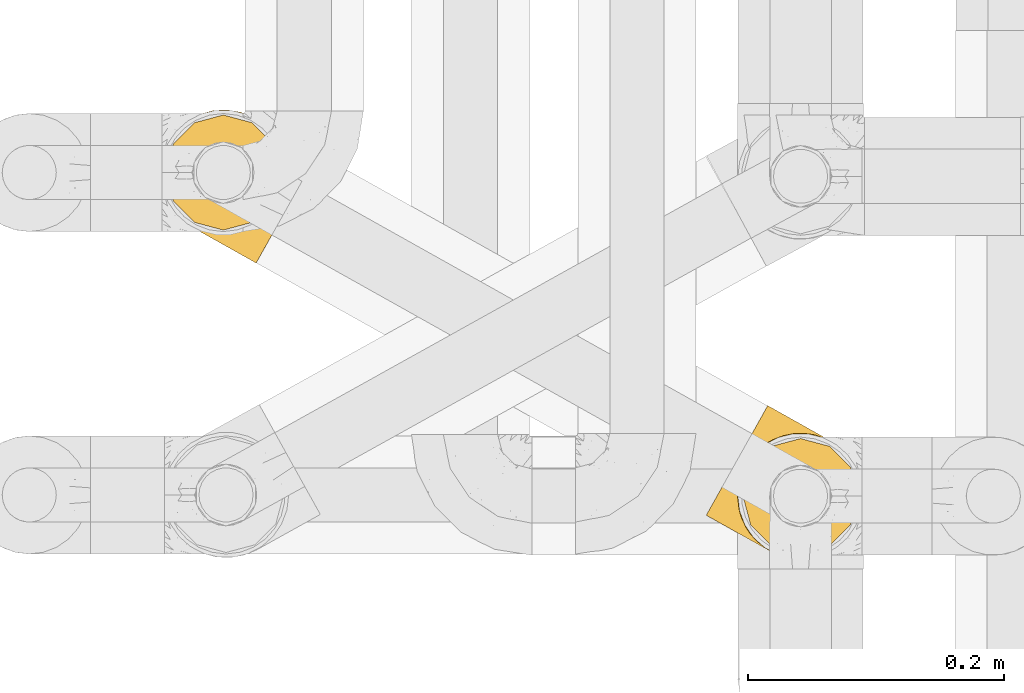
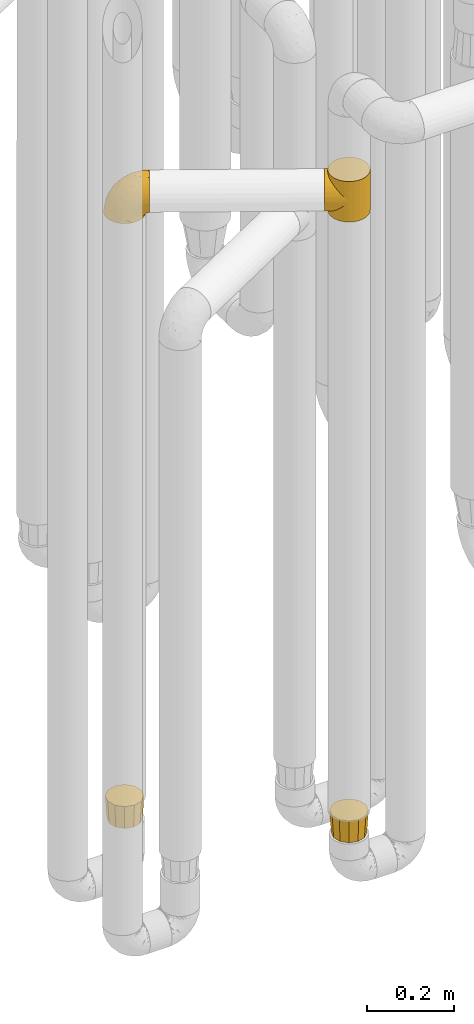
# One storey, part 155 of 827: 4 coverings.
"""IFC2X3 building model written with IfcOpenShell, lengths in millimetres."""

from ifc_helpers import new_model, entity, si_unit, converted_unit, derived_unit, direction, frame, origin, place, context, subcontext, project, spatial, faceted_brep, element, save


model = new_model("IFC2X3")

# Units and contexts
model_context = context("Model", 3, precision=0.01, world=origin(), true_north=direction((6.12303176911189e-17, 1.0)))
body_context = subcontext(model_context, "Body", "Model", "MODEL_VIEW")
ifc_project = project(units=[si_unit("LENGTHUNIT", "METRE", prefix="MILLI"), si_unit("AREAUNIT", "SQUARE_METRE"), si_unit("VOLUMEUNIT", "CUBIC_METRE"), converted_unit("PLANEANGLEUNIT", "DEGREE", entity("IfcRatioMeasure", 0.0174532925199433), si_unit("PLANEANGLEUNIT", "RADIAN"), dimensions=[0, 0, 0, 0, 0, 0, 0]), si_unit("MASSUNIT", "GRAM", prefix="KILO"), derived_unit("MASSDENSITYUNIT", [(si_unit("MASSUNIT", "GRAM", prefix="KILO"), 1), (si_unit("LENGTHUNIT", "METRE"), -3)]), derived_unit("MOMENTOFINERTIAUNIT", [(si_unit("LENGTHUNIT", "METRE"), 4)]), si_unit("TIMEUNIT", "SECOND"), si_unit("FREQUENCYUNIT", "HERTZ"), si_unit("THERMODYNAMICTEMPERATUREUNIT", "DEGREE_CELSIUS"), derived_unit("THERMALTRANSMITTANCEUNIT", [(si_unit("MASSUNIT", "GRAM", prefix="KILO"), 1), (si_unit("THERMODYNAMICTEMPERATUREUNIT", "KELVIN"), -1), (si_unit("TIMEUNIT", "SECOND"), -3)]), derived_unit("VOLUMETRICFLOWRATEUNIT", [(si_unit("LENGTHUNIT", "METRE"), 3), (si_unit("TIMEUNIT", "SECOND"), -1)]), derived_unit("MASSFLOWRATEUNIT", [(si_unit("MASSUNIT", "GRAM", prefix="KILO"), 1), (si_unit("TIMEUNIT", "SECOND"), -1)]), derived_unit("ROTATIONALFREQUENCYUNIT", [(si_unit("TIMEUNIT", "SECOND"), -1)]), si_unit("ELECTRICCURRENTUNIT", "AMPERE"), si_unit("ELECTRICVOLTAGEUNIT", "VOLT"), si_unit("POWERUNIT", "WATT"), si_unit("FORCEUNIT", "NEWTON", prefix="KILO"), si_unit("ILLUMINANCEUNIT", "LUX"), si_unit("LUMINOUSFLUXUNIT", "LUMEN"), si_unit("LUMINOUSINTENSITYUNIT", "CANDELA"), derived_unit("USERDEFINED", [(si_unit("MASSUNIT", "GRAM", prefix="KILO"), -1), (si_unit("LENGTHUNIT", "METRE"), -2), (si_unit("TIMEUNIT", "SECOND"), 3), (si_unit("LUMINOUSFLUXUNIT", "LUMEN"), 1)]), derived_unit("LINEARVELOCITYUNIT", [(si_unit("LENGTHUNIT", "METRE"), 1), (si_unit("TIMEUNIT", "SECOND"), -1)]), si_unit("PRESSUREUNIT", "PASCAL"), derived_unit("USERDEFINED", [(si_unit("LENGTHUNIT", "METRE"), -2), (si_unit("MASSUNIT", "GRAM", prefix="KILO"), 1), (si_unit("TIMEUNIT", "SECOND"), -2)]), derived_unit("LINEARFORCEUNIT", [(si_unit("MASSUNIT", "GRAM", prefix="KILO"), 1), (si_unit("LENGTHUNIT", "METRE"), 1), (si_unit("TIMEUNIT", "SECOND"), -2), (si_unit("LENGTHUNIT", "METRE"), -1)]), derived_unit("PLANARFORCEUNIT", [(si_unit("MASSUNIT", "GRAM", prefix="KILO"), 1), (si_unit("LENGTHUNIT", "METRE"), 1), (si_unit("TIMEUNIT", "SECOND"), -2), (si_unit("LENGTHUNIT", "METRE"), -2)])], contexts=[model_context])

# Site, building, storey
site_placement = place(None, origin())
site = spatial("IfcSite", under=ifc_project, at=site_placement, CompositionType="ELEMENT")
building_placement = place(site_placement, origin())
building = spatial("IfcBuilding", under=site, at=building_placement, CompositionType="ELEMENT")
storey_placement = place(building_placement, frame((0.0, 0.0, 28200.0)))
storey = spatial("IfcBuildingStorey", under=building, at=storey_placement, Name="08", CompositionType="ELEMENT", Elevation=28200.0)

# Coverings
covering_1_placement = place(storey_placement, frame((35652.7, 10305.43, 2248.0)))
element("IfcCovering", 1, at=covering_1_placement, inside=storey, Name=":ADSK_", ObjectType=":ADSK_", PredefinedType="INSULATION", context=body_context, shape_type="Brep", body=[
    faceted_brep([(45.76, 11.5, 63.62), (51.31, 7.87, 114.0), (41.04, 15.55, 114.0), (33.1, 25.63, 114.0), (36.21, 21.01, 76.6), (29.32, 33.5, 88.72), (28.04, 37.42, 114.0), (32.38, 26.89, 82.82), (51.31, 7.87, 57.0), (45.76, 11.5, 50.38), (51.31, 7.87, 0.0), (30.59, 70.51, 105.71), (30.1, 68.82, 114.0), (31.29, 71.8, 114.0), (40.7, 15.88, 70.17), (32.48, 74.78, 106.15), (32.48, 74.78, 114.0), (31.29, 71.8, 0.0), (32.48, 74.78, 7.85), (32.48, 74.78, 0.0), (27.21, 40.85, 94.16), (26.2, 50.12, 114.0), (26.96, 56.49, 114.0), (27.72, 62.86, 114.0), (27.68, 61.84, 104.0), (28.71, 66.23, 105.26), (26.24, 48.88, 98.93), (26.66, 57.44, 102.75), (28.91, 65.84, 114.0), (34.4, 77.35, 114.0), (36.32, 79.92, 114.0), (35.47, 79.0, 105.6), (38.47, 83.23, 105.06), (38.24, 82.49, 114.0), (40.16, 85.05, 114.0), (45.77, 89.99, 102.0), (45.2, 89.02, 114.0), (50.24, 92.99, 114.0), (42.12, 86.61, 103.53), (53.75, 94.89, 97.43), (56.14, 95.52, 114.0), (61.95, 98.03, 91.82), (49.76, 92.44, 99.71), (33.98, 76.89, 105.88), (62.03, 98.05, 114.0), (70.08, 99.61, 85.5), (74.73, 99.89, 114.0), (77.98, 99.82, 78.71), (87.47, 98.37, 114.0), (92.7, 96.73, 64.35), (99.39, 93.61, 114.0), (33.98, 76.89, 8.12), (85.55, 98.82, 71.62), (99.39, 93.61, 57.0), (92.7, 96.73, 49.65), (99.39, 93.61, 0.0), (124.5, 51.36, 0.0), (122.98, 38.62, 0.0), (118.22, 26.71, 0.0), (110.54, 16.43, 0.0), (100.46, 8.49, 0.0), (88.67, 3.43, 0.0), (75.97, 1.6, 0.0), (63.23, 3.11, 0.0), (41.04, 15.55, 0.0), (33.1, 25.63, 0.0), (28.04, 37.42, 0.0), (26.2, 50.12, 0.0), (26.96, 56.49, 0.0), (27.72, 62.86, 0.0), (28.91, 65.84, 0.0), (30.1, 68.82, 0.0), (34.4, 77.35, 0.0), (36.32, 79.92, 0.0), (38.24, 82.49, 0.0), (40.16, 85.05, 0.0), (45.2, 89.02, 0.0), (50.24, 92.99, 0.0), (56.14, 95.52, 0.0), (62.03, 98.05, 0.0), (74.73, 99.89, 0.0), (87.47, 98.37, 0.0), (109.66, 85.93, 0.0), (117.6, 75.85, 0.0), (122.66, 64.06, 0.0), (63.23, 3.11, 114.0), (75.97, 1.6, 114.0), (88.67, 3.43, 114.0), (100.46, 8.49, 114.0), (110.54, 16.43, 114.0), (118.22, 26.71, 114.0), (122.98, 38.62, 114.0), (124.5, 51.36, 114.0), (122.66, 64.06, 114.0), (117.6, 75.85, 114.0), (109.66, 85.93, 114.0), (40.7, 15.88, 43.83), (36.21, 21.01, 37.4), (30.59, 70.51, 8.29), (32.38, 26.89, 31.18), (29.32, 33.5, 25.28), (28.71, 66.23, 8.74), (27.21, 40.85, 19.84), (26.24, 48.88, 15.07), (27.68, 61.84, 10.0), (26.66, 57.44, 11.25), (45.77, 89.99, 12.0), (42.12, 86.61, 10.47), (53.75, 94.89, 16.57), (38.47, 83.23, 8.94), (61.95, 98.03, 22.18), (49.76, 92.44, 14.29), (35.47, 79.0, 8.4), (77.98, 99.82, 35.29), (85.55, 98.82, 42.38), (70.08, 99.61, 28.5), (2.41, 37.21, 69.72), (4.82, 41.49, 81.57), (8.64, 48.3, 91.75), (13.61, 57.18, 99.57), (16.51, 62.35, 102.02), (19.41, 67.52, 104.48), (20.97, 70.29, 104.89), (22.52, 73.07, 105.31), (24.08, 75.84, 105.73), (25.63, 78.62, 106.15), (27.19, 81.39, 105.73), (28.74, 84.16, 105.31), (30.3, 86.94, 104.89), (31.85, 89.71, 104.48), (34.75, 94.88, 102.02), (37.65, 100.05, 99.57), (40.14, 104.49, 95.66), (42.63, 108.93, 91.75), (46.45, 115.74, 81.57), (48.85, 120.03, 69.72), (49.67, 121.49, 57.0), (48.85, 120.03, 44.28), (46.45, 115.74, 32.42), (42.63, 108.93, 22.25), (40.14, 104.49, 18.34), (37.65, 100.05, 14.43), (34.75, 94.88, 11.98), (31.85, 89.71, 9.52), (30.3, 86.94, 9.11), (28.74, 84.16, 8.69), (27.19, 81.39, 8.27), (25.63, 78.62, 7.85), (24.08, 75.84, 8.27), (22.52, 73.07, 8.69), (20.97, 70.29, 9.11), (19.41, 67.52, 9.52), (16.51, 62.35, 11.98), (13.61, 57.18, 14.43), (8.64, 48.3, 22.25), (4.82, 41.49, 32.42), (2.41, 37.21, 44.28), (1.6, 35.74, 57.0)], [[[0, 1, 2]], [[2, 3, 4]], [[5, 3, 6]], [[5, 7, 3]], [[0, 8, 1]], [[8, 9, 10]], [[11, 12, 13]], [[4, 14, 2]], [[7, 4, 3]], [[0, 2, 14]], [[15, 13, 16]], [[17, 18, 19]], [[20, 6, 21]], [[22, 23, 24]], [[15, 11, 13]], [[23, 25, 24]], [[26, 20, 21]], [[27, 21, 22]], [[27, 22, 24]], [[25, 12, 11]], [[25, 23, 28, 12]], [[26, 21, 27]], [[6, 20, 5]], [[29, 30, 31]], [[32, 30, 33, 34]], [[35, 36, 37]], [[38, 36, 35]], [[38, 32, 34]], [[39, 37, 40]], [[41, 39, 40]], [[35, 37, 39, 42]], [[43, 16, 29]], [[40, 44, 41]], [[45, 44, 46]], [[47, 46, 48]], [[49, 48, 50]], [[47, 45, 46]], [[16, 43, 15]], [[51, 19, 18]], [[49, 52, 48]], [[53, 49, 50]], [[54, 53, 55]], [[30, 32, 31]], [[47, 48, 52]], [[36, 38, 34]], [[44, 45, 41]], [[29, 31, 43]], [[56, 57, 58, 59, 60, 61, 62, 63, 10, 64, 65, 66, 67, 68, 69, 70, 71, 17, 19, 72, 73, 74, 75, 76, 77, 78, 79, 80, 81, 55, 82, 83, 84]], [[85, 86, 87, 88, 89, 90, 91, 92, 93, 94, 95, 50, 48, 46, 44, 40, 37, 36, 34, 33, 30, 29, 16, 13, 12, 28, 23, 22, 21, 6, 3, 2, 1]], [[88, 87, 61, 60]], [[58, 90, 89, 59]], [[89, 88, 60, 59]], [[62, 86, 85, 63]], [[1, 8, 10, 63, 85]], [[61, 87, 86, 62]], [[96, 97, 64]], [[18, 17, 98]], [[9, 96, 64]], [[10, 9, 64]], [[65, 99, 100]], [[65, 64, 97]], [[71, 101, 98]], [[65, 100, 66]], [[99, 65, 97]], [[102, 103, 67]], [[104, 68, 105]], [[104, 101, 69]], [[68, 104, 69]], [[103, 105, 67]], [[66, 102, 67]], [[101, 71, 70, 69]], [[68, 67, 105]], [[98, 17, 71]], [[102, 66, 100]], [[106, 76, 107]], [[106, 77, 76]], [[77, 108, 78]], [[109, 75, 74, 73]], [[110, 78, 108]], [[111, 108, 77, 106]], [[19, 51, 72]], [[109, 73, 112]], [[72, 51, 112]], [[76, 75, 107]], [[110, 79, 78]], [[75, 109, 107]], [[113, 114, 81]], [[114, 54, 81]], [[79, 115, 80]], [[115, 79, 110]], [[113, 80, 115]], [[113, 81, 80]], [[54, 55, 81]], [[112, 73, 72]], [[53, 50, 95, 82, 55]], [[82, 95, 94, 83]], [[94, 93, 84, 83]], [[84, 93, 92, 56]], [[56, 92, 91, 57]], [[57, 91, 90, 58]], [[116, 117, 118, 119, 120, 121, 122, 123, 124, 125, 126, 127, 128, 129, 130, 131, 132, 133, 134, 135, 136, 137, 138, 139, 140, 141, 142, 143, 144, 145, 146, 147, 148, 149, 150, 151, 152, 153, 154, 155, 156, 157]], [[25, 123, 122, 121]], [[119, 118, 20]], [[15, 124, 11]], [[27, 120, 119]], [[124, 15, 125]], [[124, 123, 11]], [[120, 24, 121]], [[26, 27, 119]], [[20, 26, 119]], [[24, 120, 27]], [[25, 121, 24]], [[118, 5, 20]], [[7, 5, 117]], [[117, 5, 118]], [[4, 117, 116]], [[0, 116, 157]], [[4, 7, 117]], [[0, 14, 116]], [[8, 0, 157]], [[4, 116, 14]], [[123, 25, 11]], [[9, 157, 156]], [[156, 155, 97]], [[100, 155, 154]], [[100, 99, 155]], [[9, 8, 157]], [[98, 149, 148]], [[97, 96, 156]], [[99, 97, 155]], [[9, 156, 96]], [[18, 148, 147]], [[102, 154, 153]], [[152, 151, 104]], [[18, 98, 148]], [[151, 101, 104]], [[103, 102, 153]], [[105, 153, 152]], [[105, 152, 104]], [[101, 149, 98]], [[101, 151, 150, 149]], [[103, 153, 105]], [[154, 102, 100]], [[146, 145, 112]], [[109, 145, 144, 143]], [[106, 142, 141]], [[107, 142, 106]], [[107, 109, 143]], [[108, 141, 140]], [[110, 108, 140]], [[106, 141, 108, 111]], [[51, 147, 146]], [[140, 139, 110]], [[115, 139, 138]], [[113, 138, 137]], [[54, 137, 136]], [[113, 115, 138]], [[147, 51, 18]], [[54, 114, 137]], [[53, 54, 136]], [[145, 109, 112]], [[113, 137, 114]], [[142, 107, 143]], [[139, 115, 110]], [[146, 112, 51]], [[49, 136, 135]], [[135, 134, 47]], [[45, 134, 133]], [[45, 47, 134]], [[43, 125, 15]], [[49, 53, 136]], [[32, 129, 128, 127]], [[47, 52, 135]], [[49, 135, 52]], [[31, 127, 126]], [[131, 35, 42, 39]], [[125, 43, 126]], [[39, 132, 131]], [[130, 129, 38]], [[43, 31, 126]], [[41, 133, 132]], [[41, 132, 39]], [[35, 130, 38]], [[32, 127, 31]], [[35, 131, 130]], [[129, 32, 38]], [[133, 41, 45]]]),
])
covering_2_placement = place(storey_placement, frame((35681.45, 10309.57, 495.0)))
element("IfcCovering", 2, at=covering_2_placement, inside=storey, Name=":ADSK_", ObjectType=":ADSK_", PredefinedType="INSULATION", context=body_context, shape_type="Brep", body=[
    faceted_brep([(85.57, 24.1, 64.0), (88.01, 33.21, 64.0), (91.6, 46.6, 64.0), (88.01, 59.99, 64.0), (85.57, 69.1, 64.0), (77.33, 77.33, 64.0), (69.1, 85.57, 64.0), (59.99, 88.01, 64.0), (46.6, 91.6, 64.0), (33.21, 88.01, 64.0), (24.1, 85.57, 64.0), (15.86, 77.33, 64.0), (7.62, 69.1, 64.0), (5.18, 59.99, 64.0), (1.6, 46.6, 64.0), (5.18, 33.21, 64.0), (7.62, 24.1, 64.0), (15.86, 15.86, 64.0), (24.1, 7.62, 64.0), (33.21, 5.18, 64.0), (46.6, 1.6, 64.0), (59.99, 5.18, 64.0), (69.1, 7.62, 64.0), (77.33, 15.86, 64.0), (82.1, 26.1, 0.0), (74.6, 18.59, 0.0), (67.1, 11.09, 0.0), (56.85, 8.34, 0.0), (46.6, 5.6, 0.0), (36.35, 8.34, 0.0), (26.1, 11.09, 0.0), (18.59, 18.59, 0.0), (11.09, 26.1, 0.0), (8.34, 36.35, 0.0), (5.6, 46.6, 0.0), (8.34, 56.85, 0.0), (11.09, 67.1, 0.0), (18.59, 74.6, 0.0), (26.1, 82.1, 0.0), (36.35, 84.85, 0.0), (46.6, 87.6, 0.0), (56.85, 84.85, 0.0), (67.1, 82.1, 0.0), (74.6, 74.6, 0.0), (82.1, 67.1, 0.0), (84.85, 56.85, 0.0), (87.6, 46.6, 0.0), (84.85, 36.35, 0.0)], [[[0, 1, 2, 3, 4, 5, 6, 7, 8, 9, 10, 11, 12, 13, 14, 15, 16, 17, 18, 19, 20, 21, 22, 23]], [[24, 25, 26, 27, 28, 29, 30, 31, 32, 33, 34, 35, 36, 37, 38, 39, 40, 41, 42, 43, 44, 45, 46, 47]], [[38, 10, 9, 8, 40, 39]], [[11, 10, 38, 37, 36, 12]], [[35, 34, 14, 13, 12, 36]], [[32, 16, 15, 14, 34, 33]], [[17, 16, 32, 31, 30, 18]], [[29, 28, 20, 19, 18, 30]], [[26, 22, 21, 20, 28, 27]], [[23, 22, 26, 25, 24, 0]], [[47, 46, 2, 1, 0, 24]], [[44, 4, 3, 2, 46, 45]], [[5, 4, 44, 43, 42, 6]], [[41, 40, 8, 7, 6, 42]]]),
])
covering_3_placement = place(storey_placement, frame((35230.14, 10562.55, 540.0)))
element("IfcCovering", 3, at=covering_3_placement, inside=storey, Name=":ADSK_", ObjectType=":ADSK_", PredefinedType="INSULATION", context=body_context, shape_type="Brep", body=[
    faceted_brep([(7.62, 69.1, 64.0), (5.18, 59.99, 64.0), (1.6, 46.6, 64.0), (5.18, 33.21, 64.0), (7.62, 24.1, 64.0), (15.86, 15.86, 64.0), (24.1, 7.62, 64.0), (33.21, 5.18, 64.0), (46.6, 1.6, 64.0), (59.99, 5.18, 64.0), (69.1, 7.62, 64.0), (77.33, 15.86, 64.0), (85.57, 24.1, 64.0), (88.01, 33.21, 64.0), (91.6, 46.6, 64.0), (88.01, 59.99, 64.0), (85.57, 69.1, 64.0), (77.33, 77.33, 64.0), (69.1, 85.57, 64.0), (59.99, 88.01, 64.0), (46.6, 91.6, 64.0), (33.21, 88.01, 64.0), (24.1, 85.57, 64.0), (15.86, 77.33, 64.0), (11.09, 67.1, 0.0), (18.59, 74.6, 0.0), (26.1, 82.1, 0.0), (36.35, 84.85, 0.0), (46.6, 87.6, 0.0), (56.85, 84.85, 0.0), (67.1, 82.1, 0.0), (74.6, 74.6, 0.0), (82.1, 67.1, 0.0), (84.85, 56.85, 0.0), (87.6, 46.6, 0.0), (84.85, 36.35, 0.0), (82.1, 26.1, 0.0), (74.6, 18.59, 0.0), (67.1, 11.09, 0.0), (56.85, 8.34, 0.0), (46.6, 5.6, 0.0), (36.35, 8.34, 0.0), (26.1, 11.09, 0.0), (18.59, 18.59, 0.0), (11.09, 26.1, 0.0), (8.34, 36.35, 0.0), (5.6, 46.6, 0.0), (8.34, 56.85, 0.0)], [[[0, 1, 2, 3, 4, 5, 6, 7, 8, 9, 10, 11, 12, 13, 14, 15, 16, 17, 18, 19, 20, 21, 22, 23]], [[24, 25, 26, 27, 28, 29, 30, 31, 32, 33, 34, 35, 36, 37, 38, 39, 40, 41, 42, 43, 44, 45, 46, 47]], [[38, 10, 9, 8, 40, 39]], [[11, 10, 38, 37, 36, 12]], [[35, 34, 14, 13, 12, 36]], [[32, 16, 15, 14, 34, 33]], [[17, 16, 32, 31, 30, 18]], [[29, 28, 20, 19, 18, 30]], [[26, 22, 21, 20, 28, 27]], [[23, 22, 26, 25, 24, 0]], [[47, 46, 2, 1, 0, 24]], [[44, 4, 3, 2, 46, 45]], [[5, 4, 44, 43, 42, 6]], [[41, 40, 8, 7, 6, 42]]]),
])
covering_4_placement = place(storey_placement, frame((35226.09, 10536.79, 2246.4)))
element("IfcCovering", 4, at=covering_4_placement, inside=storey, Name=":ADSK_", ObjectType=":ADSK_", PredefinedType="INSULATION", context=body_context, shape_type="Brep", body=[
    faceted_brep([(26.62, 29.46, 1.6), (17.68, 35.89, 1.6), (10.39, 44.14, 1.6), (5.13, 53.81, 1.6), (2.15, 64.4, 1.6), (1.6, 75.39, 1.6), (3.5, 86.23, 1.6), (7.78, 96.37, 1.6), (14.2, 105.31, 1.6), (22.45, 112.6, 1.6), (32.12, 117.86, 1.6), (42.71, 120.84, 1.6), (53.71, 121.39, 1.6), (64.54, 119.48, 1.6), (74.68, 115.21, 1.6), (79.34, 111.87, 1.6), (83.62, 108.79, 1.6), (87.27, 104.66, 1.6), (90.91, 100.53, 1.6), (96.17, 90.87, 1.6), (99.16, 80.27, 1.6), (99.71, 69.28, 1.6), (97.8, 58.45, 1.6), (93.53, 48.31, 1.6), (87.1, 39.37, 1.6), (78.85, 32.08, 1.6), (69.18, 26.82, 1.6), (58.59, 23.83, 1.6), (47.59, 23.28, 1.6), (42.18, 24.24, 1.6), (36.76, 25.19, 1.6), (31.91, 27.24, 1.6), (29.26, 28.35, 1.6), (106.59, 55.57, 11.12), (112.39, 65.91, 16.03), (114.88, 70.35, 19.94), (117.36, 74.79, 23.84), (119.27, 78.19, 28.93), (121.18, 81.6, 34.02), (122.38, 83.74, 39.95), (123.58, 85.88, 45.87), (124.03, 86.69, 52.86), (124.22, 87.02, 55.73), (124.4, 87.35, 58.6), (123.58, 85.88, 71.32), (121.18, 81.6, 83.17), (117.36, 74.79, 93.35), (112.39, 65.91, 101.16), (106.59, 55.57, 106.07), (100.37, 44.47, 107.75), (94.15, 33.37, 106.07), (88.36, 23.03, 101.16), (83.38, 14.15, 93.35), (79.56, 7.34, 83.17), (77.16, 3.06, 71.32), (76.34, 1.6, 58.6), (76.71, 2.25, 52.86), (77.16, 3.06, 45.87), (78.36, 5.2, 39.95), (79.56, 7.34, 34.02), (81.47, 10.75, 28.93), (83.38, 14.15, 23.84), (85.87, 18.59, 19.94), (88.36, 23.03, 16.03), (94.15, 33.37, 11.12), (100.37, 44.47, 9.45), (36.55, 70.43, 81.82), (38.87, 53.34, 84.02), (50.1, 57.78, 93.05), (71.76, 60.51, 102.55), (77.51, 48.23, 104.83), (89.83, 50.38, 105.83), (52.83, 41.32, 91.87), (70.58, 41.75, 101.74), (70.38, 28.98, 97.07), (17.37, 41.05, 38.45), (20.82, 34.01, 22.17), (28.26, 30.26, 42.04), (59.61, 17.08, 77.69), (42.05, 32.26, 75.76), (38.86, 26.7, 62.11), (59.81, 12.14, 66.08), (57.31, 12.26, 54.26), (62.1, 9.58, 55.35), (66.89, 6.89, 56.44), (69.25, 5.57, 56.98), (71.61, 4.25, 57.52), (60.54, 24.88, 87.84), (13.02, 42.0, 19.41), (13.68, 81.96, 48.89), (5.2, 81.2, 26.34), (9.92, 69.81, 44.55), (30.4, 27.34, 23.41), (33.1, 25.83, 28.03), (35.79, 24.32, 32.65), (38.49, 22.81, 37.28), (41.18, 21.3, 41.9), (7.97, 50.52, 20.6), (20.71, 74.91, 63.36), (29.67, 36.92, 62.21), (2.99, 70.96, 19.94), (9.45, 95.43, 13.68), (39.65, 42.47, 80.85), (26.53, 46.49, 66.53), (26.54, 55.84, 71.06), (25.46, 86.46, 63.99), (35.7, 80.72, 75.73), (5.53, 60.64, 26.77), (27.09, 29.2, 4.31), (27.56, 28.94, 7.01), (28.5, 28.41, 12.43), (29.45, 27.88, 17.92), (13.03, 51.71, 43.43), (16.95, 56.71, 56.23), (43.69, 20.73, 54.97), (12.31, 93.83, 34.4), (45.22, 19.04, 44.99), (49.25, 16.78, 48.08), (53.28, 14.52, 51.17), (45.95, 74.98, 87.47), (28.49, 65.43, 74.55), (18.3, 65.82, 60.86), (18.88, 90.14, 49.19), (58.85, 67.74, 95.01), (37.36, 24.83, 10.27), (70.51, 5.87, 48.79), (62.33, 10.71, 45.16), (68.33, 7.92, 44.99), (82.8, 33.96, 6.17), (75.33, 28.61, 7.65), (41.33, 22.77, 21.59), (36.67, 24.51, 19.96), (78.79, 18.94, 21.0), (74.75, 14.44, 27.2), (82.57, 25.77, 14.83), (73.4, 20.48, 19.7), (78.1, 28.13, 10.93), (88.48, 35.05, 9.63), (61.7, 20.19, 19.97), (53.74, 20.31, 21.13), (59.24, 22.1, 14.14), (76.1, 11.72, 30.2), (60.15, 23.57, 8.12), (67.33, 24.74, 9.93), (63.68, 18.03, 24.62), (44.1, 23.14, 11.87), (95.53, 47.18, 7.15), (89.64, 41.05, 5.32), (44.65, 21.11, 26.68), (69.61, 23.69, 13.92), (51.17, 18.42, 30.67), (68.73, 10.84, 36.65), (58.26, 13.03, 42.89), (64.7, 13.44, 34.04), (54.53, 15.94, 36.6), (68.97, 16.32, 26.41), (51.85, 22.64, 10.07), (52.24, 21.67, 15.83), (53.79, 15.15, 41.99), (107.04, 69.41, 14.83), (108.0, 85.94, 26.4), (110.9, 76.2, 21.01), (106.77, 79.98, 19.71), (100.25, 67.82, 5.72), (88.06, 106.16, 21.6), (84.15, 109.22, 19.96), (81.16, 111.58, 28.03), (89.21, 103.59, 11.87), (99.96, 82.93, 9.93), (122.04, 88.67, 58.06), (114.95, 92.64, 56.44), (119.68, 89.99, 57.52), (97.22, 89.66, 8.13), (98.0, 91.22, 14.15), (114.82, 90.88, 44.99), (112.54, 89.01, 36.65), (115.64, 82.27, 30.2), (93.69, 97.21, 10.06), (94.71, 97.41, 15.83), (117.71, 90.08, 48.79), (105.21, 96.8, 42.89), (109.16, 94.69, 45.38), (76.56, 114.16, 12.43), (84.25, 108.47, 10.28), (102.21, 59.53, 9.64), (110.16, 95.33, 55.35), (105.38, 98.01, 54.26), (99.12, 59.11, 6.05), (75.62, 114.69, 7.01), (76.09, 114.42, 9.72), (83.85, 110.07, 32.65), (91.22, 104.2, 26.68), (102.05, 81.54, 13.92), (86.55, 108.56, 37.28), (96.94, 100.0, 30.66), (96.65, 96.85, 21.14), (100.78, 98.46, 36.59), (103.79, 89.54, 24.6), (77.51, 113.63, 17.92), (78.47, 113.09, 23.41), (102.69, 71.98, 10.93), (100.91, 90.12, 19.97), (101.07, 99.51, 41.99), (97.31, 102.53, 48.08), (108.22, 91.1, 34.04), (112.62, 82.0, 27.21), (101.34, 100.27, 51.17), (93.28, 104.79, 44.99), (89.24, 107.05, 41.9), (90.74, 105.29, 55.26), (85.23, 62.01, 104.83), (96.29, 88.68, 87.84), (80.64, 100.45, 75.91), (70.45, 97.32, 80.84), (78.24, 86.67, 91.87), (60.7, 92.35, 83.98), (56.68, 120.31, 19.16), (67.54, 117.84, 22.37), (106.78, 95.95, 66.08), (62.78, 80.41, 93.05), (87.14, 71.3, 101.74), (97.93, 78.14, 97.07), (102.46, 93.54, 77.69), (31.57, 108.41, 44.55), (19.39, 106.49, 26.34), (23.16, 98.86, 48.9), (52.09, 101.56, 70.99), (44.98, 94.85, 74.55), (59.84, 117.21, 37.8), (32.83, 96.49, 63.4), (44.92, 85.36, 81.82), (37.1, 116.94, 26.77), (47.0, 120.13, 20.6), (46.28, 109.24, 56.15), (39.29, 103.32, 60.85), (74.83, 113.4, 42.06), (66.53, 111.08, 57.03), (26.97, 113.72, 19.94), (48.7, 115.16, 43.59), (82.85, 106.21, 62.61), (60.12, 106.41, 66.52)], [[[0, 1, 2, 3, 4, 5, 6, 7, 8, 9, 10, 11, 12, 13, 14, 15, 16, 17, 18, 19, 20, 21, 22, 23, 24, 25, 26, 27, 28, 29, 30, 31, 32]], [[33, 34, 35, 36, 37, 38, 39, 40, 41, 42, 43, 44, 45, 46, 47, 48, 49, 50, 51, 52, 53, 54, 55, 56, 57, 58, 59, 60, 61, 62, 63, 64, 65]], [[66, 67, 68]], [[69, 70, 71]], [[68, 72, 73]], [[73, 72, 74]], [[75, 76, 77]], [[78, 79, 80]], [[51, 50, 73]], [[81, 82, 83, 84, 85, 86, 55]], [[52, 87, 53]], [[74, 52, 51]], [[2, 1, 88]], [[89, 90, 91]], [[77, 92, 93, 94, 95, 96]], [[55, 54, 81]], [[78, 53, 87]], [[5, 90, 6]], [[88, 76, 75]], [[97, 3, 2]], [[89, 91, 98]], [[99, 80, 79]], [[90, 5, 100]], [[74, 87, 52]], [[100, 5, 4]], [[90, 101, 6]], [[79, 102, 103]], [[102, 67, 104]], [[105, 98, 106]], [[107, 4, 3]], [[76, 0, 108, 109, 110, 111, 92]], [[107, 112, 113]], [[114, 77, 96]], [[89, 115, 90]], [[114, 96, 116, 117, 118, 82]], [[75, 97, 88]], [[119, 66, 68]], [[50, 71, 70]], [[100, 91, 90]], [[99, 77, 80]], [[102, 104, 103]], [[97, 107, 3]], [[80, 81, 78]], [[107, 97, 112]], [[68, 73, 70]], [[66, 98, 120]], [[78, 81, 54]], [[114, 81, 80]], [[53, 78, 54]], [[78, 87, 79]], [[102, 87, 72]], [[79, 103, 99]], [[4, 107, 100]], [[91, 100, 107]], [[88, 97, 2]], [[112, 97, 75]], [[99, 112, 75]], [[103, 104, 113]], [[91, 121, 98]], [[89, 105, 122, 115]], [[101, 90, 115]], [[101, 7, 6]], [[88, 1, 76]], [[0, 76, 1]], [[92, 77, 76]], [[73, 74, 51]], [[87, 74, 72]], [[81, 114, 82]], [[77, 114, 80]], [[87, 102, 79]], [[67, 102, 72]], [[68, 67, 72]], [[67, 120, 104]], [[120, 121, 104]], [[104, 121, 113]], [[121, 120, 98]], [[91, 107, 113]], [[91, 113, 121]], [[103, 113, 112]], [[66, 119, 106]], [[105, 89, 98]], [[68, 69, 123, 119]], [[67, 66, 120]], [[98, 66, 106]], [[50, 49, 71]], [[50, 70, 73]], [[112, 99, 103]], [[77, 99, 75]], [[69, 68, 70]], [[29, 124, 110]], [[84, 83, 125]], [[126, 82, 118]], [[59, 58, 127]], [[25, 128, 129]], [[130, 93, 131]], [[132, 62, 133]], [[134, 135, 136]], [[137, 65, 64]], [[64, 134, 137]], [[138, 139, 140]], [[111, 110, 124, 92]], [[134, 136, 137]], [[134, 64, 63]], [[133, 61, 141]], [[125, 58, 57]], [[142, 143, 140]], [[142, 26, 143]], [[127, 83, 82]], [[28, 124, 29]], [[108, 0, 32, 31, 30, 110, 109]], [[30, 29, 110]], [[135, 144, 138]], [[28, 145, 124]], [[57, 56, 55, 86, 85, 84]], [[146, 147, 23]], [[24, 23, 147]], [[25, 143, 26]], [[95, 94, 148]], [[24, 128, 25]], [[149, 138, 143]], [[124, 145, 131]], [[127, 58, 125]], [[150, 148, 139]], [[127, 126, 151]], [[151, 59, 127]], [[152, 151, 126]], [[153, 154, 155]], [[153, 133, 141]], [[145, 28, 27]], [[142, 156, 27]], [[157, 148, 130]], [[61, 133, 62]], [[134, 132, 135]], [[147, 128, 24]], [[65, 137, 146]], [[146, 137, 147]], [[128, 137, 136]], [[137, 128, 147]], [[128, 136, 129]], [[149, 129, 136]], [[25, 129, 143]], [[158, 152, 117]], [[152, 118, 117]], [[153, 151, 152]], [[158, 116, 154]], [[144, 150, 138]], [[153, 152, 158]], [[133, 153, 155]], [[133, 155, 132]], [[141, 61, 60]], [[135, 132, 155]], [[134, 63, 132]], [[144, 135, 155]], [[135, 138, 149]], [[155, 154, 144]], [[150, 154, 96]], [[154, 150, 144]], [[148, 94, 130]], [[82, 126, 127]], [[118, 152, 126]], [[150, 96, 95]], [[139, 148, 157]], [[150, 95, 148]], [[93, 92, 131]], [[130, 145, 156]], [[130, 94, 93]], [[84, 125, 57]], [[127, 125, 83]], [[140, 139, 157]], [[150, 139, 138]], [[140, 157, 142]], [[138, 140, 143]], [[156, 142, 157]], [[27, 26, 142]], [[130, 156, 157]], [[145, 27, 156]], [[132, 63, 62]], [[124, 131, 92]], [[130, 131, 145]], [[129, 149, 143]], [[135, 149, 136]], [[60, 151, 141]], [[59, 151, 60]], [[141, 151, 153]], [[116, 96, 154]], [[153, 158, 154]], [[158, 117, 116]], [[34, 33, 159]], [[160, 161, 162]], [[22, 21, 163]], [[164, 165, 166]], [[19, 18, 167]], [[168, 21, 20]], [[169, 43, 42, 41, 40, 170, 171]], [[172, 173, 168]], [[174, 38, 175]], [[176, 37, 36]], [[177, 164, 178]], [[40, 179, 170]], [[180, 181, 175]], [[17, 182, 183]], [[65, 146, 184]], [[185, 174, 186]], [[23, 22, 187]], [[174, 39, 38]], [[15, 14, 188, 189, 182, 16]], [[179, 40, 39]], [[190, 191, 164]], [[192, 163, 168]], [[33, 184, 159]], [[178, 173, 172]], [[193, 194, 191]], [[18, 183, 167]], [[173, 178, 195]], [[196, 197, 194]], [[198, 199, 183, 182]], [[182, 17, 16]], [[18, 17, 183]], [[200, 159, 184]], [[192, 168, 201]], [[187, 163, 200]], [[202, 203, 180]], [[185, 179, 174]], [[160, 204, 205]], [[206, 181, 180]], [[206, 180, 203]], [[199, 165, 183]], [[165, 164, 167]], [[172, 177, 178]], [[200, 192, 162]], [[205, 161, 160]], [[65, 184, 33]], [[163, 187, 22]], [[175, 204, 180]], [[174, 181, 186]], [[204, 196, 202]], [[197, 160, 162]], [[196, 207, 202]], [[205, 204, 176]], [[196, 204, 160]], [[176, 204, 175]], [[205, 35, 161]], [[34, 159, 161]], [[162, 161, 159]], [[200, 162, 159]], [[197, 162, 201]], [[194, 197, 201]], [[196, 160, 197]], [[191, 195, 178]], [[208, 196, 194]], [[186, 181, 206]], [[175, 181, 174]], [[191, 190, 193]], [[193, 208, 194]], [[195, 194, 201]], [[178, 164, 191]], [[168, 163, 21]], [[166, 165, 199]], [[166, 190, 164]], [[187, 200, 184]], [[184, 146, 187]], [[23, 187, 146]], [[174, 179, 39]], [[170, 179, 185]], [[194, 195, 191]], [[173, 201, 168]], [[201, 173, 195]], [[172, 168, 20]], [[20, 19, 172]], [[177, 172, 19]], [[19, 167, 177]], [[164, 177, 167]], [[35, 205, 36]], [[35, 34, 161]], [[183, 165, 167]], [[162, 192, 201]], [[163, 192, 200]], [[175, 38, 37]], [[205, 176, 36]], [[175, 37, 176]], [[204, 202, 180]], [[207, 196, 208]], [[207, 203, 202]], [[209, 186, 206, 203, 207, 208]], [[48, 210, 71]], [[211, 212, 213]], [[214, 213, 215]], [[216, 217, 13]], [[218, 43, 169, 171, 170, 185, 186]], [[219, 220, 214]], [[47, 46, 221]], [[210, 48, 220]], [[211, 222, 212]], [[222, 45, 44]], [[221, 220, 47]], [[47, 220, 48]], [[221, 211, 214]], [[223, 224, 225]], [[211, 46, 45]], [[226, 227, 215]], [[43, 218, 44]], [[217, 216, 228]], [[227, 229, 230]], [[14, 13, 217]], [[224, 9, 8]], [[10, 231, 11]], [[11, 232, 12]], [[233, 223, 234]], [[235, 208, 193, 190, 166, 199]], [[236, 235, 228]], [[222, 44, 218]], [[106, 230, 229]], [[224, 237, 9]], [[232, 238, 228]], [[9, 237, 10]], [[115, 224, 101]], [[239, 235, 236]], [[232, 11, 231]], [[223, 231, 237]], [[224, 8, 101]], [[223, 229, 234]], [[225, 115, 122, 105]], [[216, 12, 232]], [[209, 235, 239]], [[210, 219, 69]], [[219, 214, 215]], [[230, 119, 219]], [[209, 218, 186]], [[239, 212, 222]], [[239, 222, 218]], [[45, 222, 211]], [[236, 212, 239]], [[213, 212, 240]], [[223, 237, 224]], [[231, 10, 237]], [[238, 232, 231]], [[216, 232, 228]], [[233, 231, 223]], [[236, 238, 240]], [[115, 225, 224]], [[234, 229, 227]], [[8, 7, 101]], [[235, 209, 208]], [[218, 209, 239]], [[217, 228, 235]], [[13, 12, 216]], [[235, 199, 217]], [[217, 199, 198, 182, 189, 188, 14]], [[211, 221, 46]], [[220, 221, 214]], [[71, 210, 69]], [[71, 49, 48]], [[219, 210, 220]], [[226, 215, 213]], [[211, 213, 214]], [[226, 213, 240]], [[215, 227, 230]], [[233, 240, 238]], [[234, 227, 226]], [[233, 234, 226]], [[229, 223, 225]], [[240, 233, 226]], [[233, 238, 231]], [[225, 105, 229]], [[229, 105, 106]], [[106, 119, 230]], [[123, 69, 219, 119]], [[215, 230, 219]], [[238, 236, 228]], [[212, 236, 240]]]),
])

save(model, "model.ifc")
